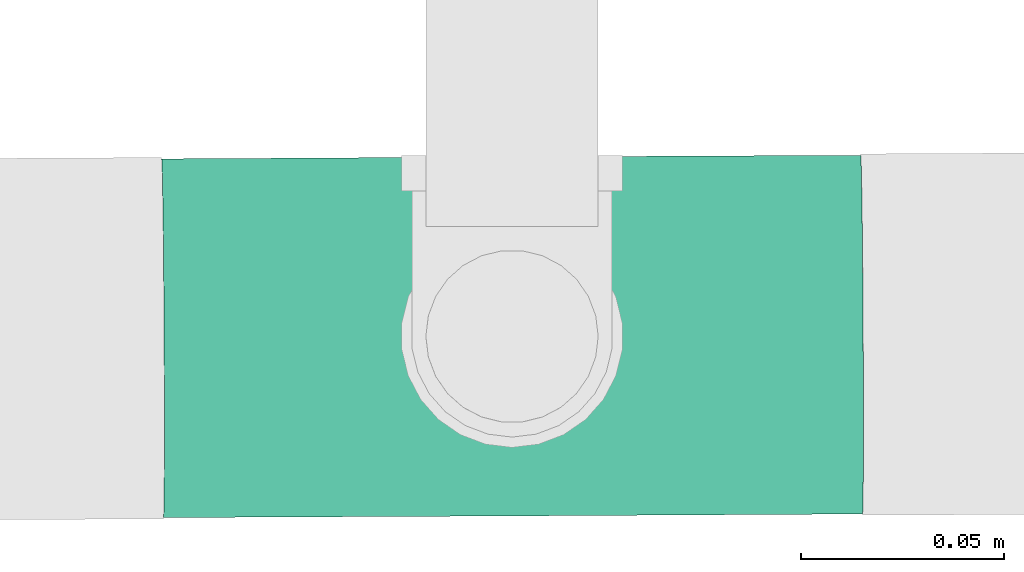
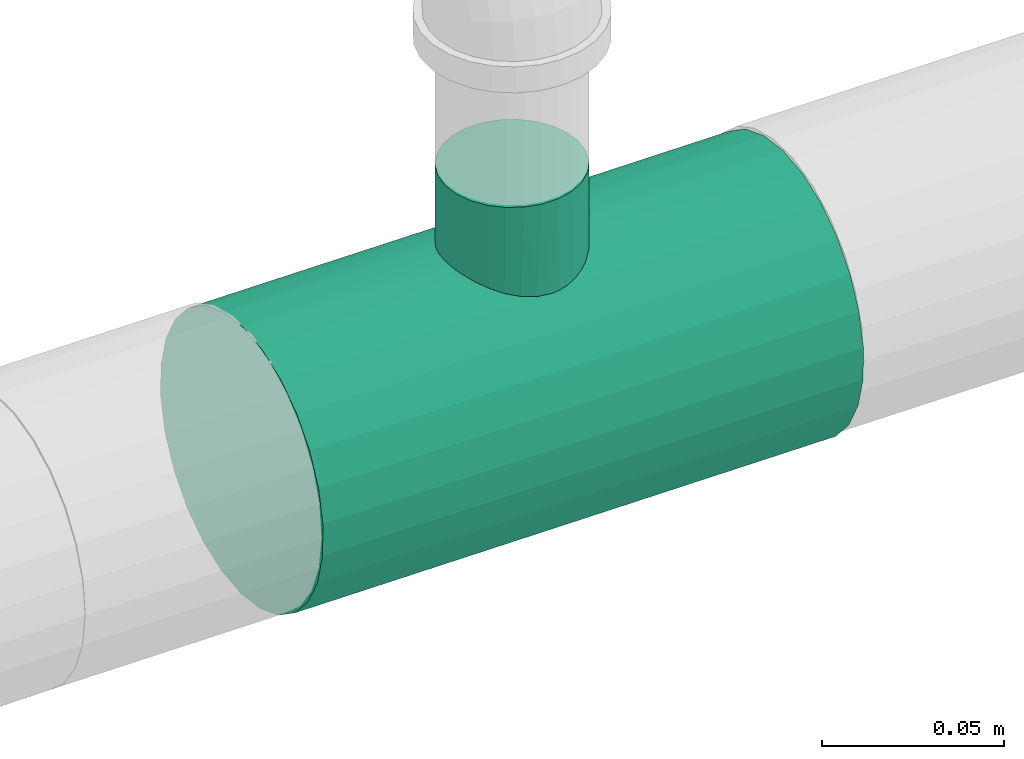
# One storey, part 2 of 7: 1 pipe fitting.
"""IFC4 building model written with IfcOpenShell, lengths in millimetres."""

from ifc_helpers import new_model, entity, si_unit, converted_unit, derived_unit, direction, frame, origin, place, context, subcontext, project, spatial, source, transform, mapped, type_object, type_shapes, element, save


model = new_model("IFC4")

# Units and contexts
model_context = context("Model", 3, precision=0.01, world=origin(), true_north=direction((6.12303176911189e-17, 1.0)))
body_context = subcontext(model_context, "Body", "Model", "MODEL_VIEW")
ifc_project = project(units=[si_unit("LENGTHUNIT", "METRE", prefix="MILLI"), si_unit("AREAUNIT", "SQUARE_METRE"), si_unit("VOLUMEUNIT", "CUBIC_METRE"), converted_unit("PLANEANGLEUNIT", "DEGREE", entity("IfcRatioMeasure", 0.0174532925199433), si_unit("PLANEANGLEUNIT", "RADIAN"), dimensions=[0, 0, 0, 0, 0, 0, 0]), si_unit("MASSUNIT", "GRAM", prefix="KILO"), derived_unit("MASSDENSITYUNIT", [(si_unit("MASSUNIT", "GRAM", prefix="KILO"), 1), (si_unit("LENGTHUNIT", "METRE"), -3)]), derived_unit("MOMENTOFINERTIAUNIT", [(si_unit("LENGTHUNIT", "METRE"), 4)]), si_unit("TIMEUNIT", "SECOND"), si_unit("FREQUENCYUNIT", "HERTZ"), si_unit("THERMODYNAMICTEMPERATUREUNIT", "DEGREE_CELSIUS"), derived_unit("THERMALTRANSMITTANCEUNIT", [(si_unit("MASSUNIT", "GRAM", prefix="KILO"), 1), (si_unit("THERMODYNAMICTEMPERATUREUNIT", "KELVIN"), -1), (si_unit("TIMEUNIT", "SECOND"), -3)]), derived_unit("VOLUMETRICFLOWRATEUNIT", [(si_unit("LENGTHUNIT", "METRE"), 3), (si_unit("TIMEUNIT", "SECOND"), -1)]), si_unit("ELECTRICCURRENTUNIT", "AMPERE"), si_unit("ELECTRICVOLTAGEUNIT", "VOLT"), si_unit("POWERUNIT", "WATT"), si_unit("FORCEUNIT", "NEWTON", prefix="KILO"), si_unit("ILLUMINANCEUNIT", "LUX"), si_unit("LUMINOUSFLUXUNIT", "LUMEN"), si_unit("LUMINOUSINTENSITYUNIT", "CANDELA"), derived_unit("USERDEFINED", [(si_unit("MASSUNIT", "GRAM", prefix="KILO"), -1), (si_unit("LENGTHUNIT", "METRE"), -2), (si_unit("TIMEUNIT", "SECOND"), 3), (si_unit("LUMINOUSFLUXUNIT", "LUMEN"), 1)]), derived_unit("LINEARVELOCITYUNIT", [(si_unit("LENGTHUNIT", "METRE"), 1), (si_unit("TIMEUNIT", "SECOND"), -1)]), si_unit("PRESSUREUNIT", "PASCAL"), derived_unit("USERDEFINED", [(si_unit("LENGTHUNIT", "METRE"), -2), (si_unit("MASSUNIT", "GRAM", prefix="KILO"), 1), (si_unit("TIMEUNIT", "SECOND"), -2)]), derived_unit("LINEARFORCEUNIT", [(si_unit("MASSUNIT", "GRAM", prefix="KILO"), 1), (si_unit("LENGTHUNIT", "METRE"), 1), (si_unit("TIMEUNIT", "SECOND"), -2), (si_unit("LENGTHUNIT", "METRE"), -1)]), derived_unit("PLANARFORCEUNIT", [(si_unit("MASSUNIT", "GRAM", prefix="KILO"), 1), (si_unit("LENGTHUNIT", "METRE"), 1), (si_unit("TIMEUNIT", "SECOND"), -2), (si_unit("LENGTHUNIT", "METRE"), -2)])], contexts=[model_context])

# Site, building, storey
site_placement = place(None, origin())
site = spatial("IfcSite", under=ifc_project, at=site_placement, CompositionType="ELEMENT")
building_placement = place(site_placement, origin())
building = spatial("IfcBuilding", under=site, at=building_placement, CompositionType="ELEMENT")
storey_placement = place(building_placement, origin())
storey = spatial("IfcBuildingStorey", under=building, at=storey_placement, Name="Ebene 1", CompositionType="ELEMENT", Elevation=0.0)

# Pipe fitting
pipe_fitting_type = type_object("IfcPipeFittingType", PredefinedType="NOTDEFINED")
cartesian_point_1 = entity("IfcCartesianPoint", [-86.0, -44.45, 0.0])
vertex_point_1 = entity("IfcVertexPoint", cartesian_point_1)
cartesian_point_2 = entity("IfcCartesianPoint", [-86.0, 44.45, 0.0])
vertex_point_2 = entity("IfcVertexPoint", cartesian_point_2)
cartesian_point_3 = entity("IfcCartesianPoint", [-86.0, 0.0, 0.0])
ifc_direction_1 = entity("IfcDirection", [-1.0, 0.0, 0.0])
ifc_direction_2 = entity("IfcDirection", [0.0, 1.0, 0.0])
edge_curve_1 = entity("IfcEdgeCurve", vertex_point_1, vertex_point_2, entity("IfcTrimmedCurve", entity("IfcCircle", entity("IfcAxis2Placement3D", cartesian_point_3, ifc_direction_1, ifc_direction_2), 44.45), [cartesian_point_1], [cartesian_point_2], True, "CARTESIAN"), True)
edge_curve_2 = entity("IfcEdgeCurve", vertex_point_2, vertex_point_1, entity("IfcTrimmedCurve", entity("IfcCircle", entity("IfcAxis2Placement3D", cartesian_point_3, ifc_direction_1, ifc_direction_2), 44.45), [cartesian_point_2], [cartesian_point_1], True, "CARTESIAN"), True)
ifc_direction_3 = entity("IfcDirection", [0.0, 0.0, 1.0])
cartesian_point_4 = entity("IfcCartesianPoint", [-20.7971681685193, -44.45, 0.0])
vertex_point_3 = entity("IfcVertexPoint", cartesian_point_4)
ifc_direction_4 = entity("IfcDirection", [1.0, 0.0, 0.0])
edge_curve_3 = entity("IfcEdgeCurve", vertex_point_1, vertex_point_3, entity("IfcTrimmedCurve", entity("IfcLine", cartesian_point_1, entity("IfcVector", ifc_direction_4, 304.8)), [cartesian_point_1], [cartesian_point_4], True, "CARTESIAN"), True)
cartesian_point_5 = entity("IfcCartesianPoint", [0.0, -39.0703008124086, 21.1970303209648])
vertex_point_4 = entity("IfcVertexPoint", cartesian_point_5)
edge_curve_4 = entity("IfcEdgeCurve", vertex_point_3, vertex_point_4, entity("IfcBSplineCurveWithKnots", 3, [cartesian_point_4, entity("IfcCartesianPoint", [-20.7894161768626, -44.45, 1.61926670883027]), entity("IfcCartesianPoint", [-20.4399996926229, -44.2752694055428, 4.76969277202615]), entity("IfcCartesianPoint", [-18.3360398797482, -43.3020524493489, 10.7769093251789]), entity("IfcCartesianPoint", [-14.6807233519097, -41.7728941152398, 15.4022309638281]), entity("IfcCartesianPoint", [-10.6730826588493, -40.5762821373456, 18.1669086000587]), entity("IfcCartesianPoint", [-8.61171482858813, -40.0775107284661, 19.2306799645881]), entity("IfcCartesianPoint", [-6.97915830976026, -39.7421088373454, 19.9129870653779]), entity("IfcCartesianPoint", [-5.28752366414808, -39.4610217520412, 20.462737400691]), entity("IfcCartesianPoint", [-3.00052122387521, -39.1863174791742, 20.9843263408341]), entity("IfcCartesianPoint", [-1.21705837571869, -39.0862641682384, 21.1676067128083]), cartesian_point_5], "UNSPECIFIED", False, "UNKNOWN", [4, 1, 1, 1, 1, 1, 1, 1, 1, 4], [0.0, 0.142857142857143, 0.285714285714286, 0.571428571428571, 0.678571428571429, 0.732142857142857, 0.785714285714286, 0.839285714285714, 0.892857142857143, 1.0], "UNSPECIFIED"), True)
cartesian_point_6 = entity("IfcCartesianPoint", [0.0, 44.45, 0.0])
vertex_point_5 = entity("IfcVertexPoint", cartesian_point_6)
cartesian_point_7 = entity("IfcCartesianPoint", [0.0, 0.0, 0.0])
edge_curve_5 = entity("IfcEdgeCurve", vertex_point_4, vertex_point_5, entity("IfcTrimmedCurve", entity("IfcCircle", entity("IfcAxis2Placement3D", cartesian_point_7, ifc_direction_1, ifc_direction_2), 44.45), [cartesian_point_5], [cartesian_point_6], True, "CARTESIAN"), True)
edge_curve_6 = entity("IfcEdgeCurve", vertex_point_5, vertex_point_2, entity("IfcTrimmedCurve", entity("IfcLine", cartesian_point_2, entity("IfcVector", ifc_direction_1, 304.8)), [cartesian_point_6], [cartesian_point_2], True, "CARTESIAN"), True)
cartesian_point_8 = entity("IfcCartesianPoint", [0.0, -39.0703008124085, -21.1970303209651])
vertex_point_6 = entity("IfcVertexPoint", cartesian_point_8)
edge_curve_7 = entity("IfcEdgeCurve", vertex_point_5, vertex_point_6, entity("IfcTrimmedCurve", entity("IfcCircle", entity("IfcAxis2Placement3D", cartesian_point_7, ifc_direction_1, ifc_direction_2), 44.45), [cartesian_point_6], [cartesian_point_8], True, "CARTESIAN"), True)
edge_curve_8 = entity("IfcEdgeCurve", vertex_point_6, vertex_point_3, entity("IfcBSplineCurveWithKnots", 3, [cartesian_point_8, entity("IfcCartesianPoint", [-1.62274450095824, -39.0915852868483, -21.157798843423]), entity("IfcCartesianPoint", [-4.75446055247149, -39.3101386510298, -20.7607749820248]), entity("IfcCartesianPoint", [-10.6981058379977, -40.4385788107955, -18.5550287703093]), entity("IfcCartesianPoint", [-16.1600850476128, -42.3479805522063, -14.0855294616885]), entity("IfcCartesianPoint", [-19.9806873775908, -44.0487569656944, -7.14794080038806]), entity("IfcCartesianPoint", [-20.7855401810342, -44.45, -2.42890006324572]), cartesian_point_4], "UNSPECIFIED", False, "UNKNOWN", [4, 1, 1, 1, 1, 4], [0.0, 0.142857142857143, 0.285714285714286, 0.571428571428571, 0.785714285714286, 1.0], "UNSPECIFIED"), True)
cartesian_point_9 = entity("IfcCartesianPoint", [86.0, -44.45, 0.0])
vertex_point_7 = entity("IfcVertexPoint", cartesian_point_9)
cartesian_point_10 = entity("IfcCartesianPoint", [86.0, 44.45, 0.0])
vertex_point_8 = entity("IfcVertexPoint", cartesian_point_10)
cartesian_point_11 = entity("IfcCartesianPoint", [86.0, 0.0, 0.0])
edge_curve_9 = entity("IfcEdgeCurve", vertex_point_7, vertex_point_8, entity("IfcTrimmedCurve", entity("IfcCircle", entity("IfcAxis2Placement3D", cartesian_point_11, ifc_direction_4, ifc_direction_2), 44.45), [cartesian_point_9], [cartesian_point_10], True, "CARTESIAN"), True)
edge_curve_10 = entity("IfcEdgeCurve", vertex_point_8, vertex_point_7, entity("IfcTrimmedCurve", entity("IfcCircle", entity("IfcAxis2Placement3D", cartesian_point_11, ifc_direction_4, ifc_direction_2), 44.45), [cartesian_point_10], [cartesian_point_9], True, "CARTESIAN"), True)
edge_curve_11 = entity("IfcEdgeCurve", vertex_point_8, vertex_point_5, entity("IfcTrimmedCurve", entity("IfcLine", cartesian_point_6, entity("IfcVector", ifc_direction_1, 304.8)), [cartesian_point_10], [cartesian_point_6], True, "CARTESIAN"), True)
cartesian_point_12 = entity("IfcCartesianPoint", [21.6045805268835, -44.45, 0.0])
vertex_point_9 = entity("IfcVertexPoint", cartesian_point_12)
edge_curve_12 = entity("IfcEdgeCurve", vertex_point_4, vertex_point_9, entity("IfcBSplineCurveWithKnots", 3, [cartesian_point_5, entity("IfcCartesianPoint", [1.66438566370079, -39.0621775691198, 21.212003057903]), entity("IfcCartesianPoint", [4.88457970874502, -39.2326753744964, 20.9041752682522]), entity("IfcCartesianPoint", [9.50257262879455, -40.0487413408101, 19.329411746474]), entity("IfcCartesianPoint", [13.5679663026614, -41.1858596793202, 16.8174467675685]), entity("IfcCartesianPoint", [17.5358931683773, -42.6178162355358, 12.9384393977207]), entity("IfcCartesianPoint", [20.743927053041, -44.0307420565211, 7.3011155274272]), entity("IfcCartesianPoint", [21.5920145015936, -44.45, 2.48196217209144]), cartesian_point_12], "UNSPECIFIED", False, "UNKNOWN", [4, 1, 1, 1, 1, 1, 4], [0.0, 0.142857142857143, 0.285714285714286, 0.428571428571429, 0.571428571428571, 0.785714285714286, 1.0], "UNSPECIFIED"), True)
edge_curve_13 = entity("IfcEdgeCurve", vertex_point_9, vertex_point_7, entity("IfcTrimmedCurve", entity("IfcLine", cartesian_point_12, entity("IfcVector", ifc_direction_4, 304.8)), [cartesian_point_12], [cartesian_point_9], True, "CARTESIAN"), True)
edge_curve_14 = entity("IfcEdgeCurve", vertex_point_9, vertex_point_6, entity("IfcBSplineCurveWithKnots", 3, [cartesian_point_12, entity("IfcCartesianPoint", [21.5962031766902, -44.45, -1.65464144806116]), entity("IfcCartesianPoint", [21.2290798982529, -44.2677642571246, -4.87065870117509]), entity("IfcCartesianPoint", [19.0147863930144, -43.2535531284132, -10.996203081152]), entity("IfcCartesianPoint", [15.1890485195202, -41.6760067352411, -15.6612143855601]), entity("IfcCartesianPoint", [11.0200533634964, -40.4704120165914, -18.400911475984]), entity("IfcCartesianPoint", [8.8815848444137, -39.9770010105982, -19.438428453853]), entity("IfcCartesianPoint", [7.18963129308835, -39.6503670366119, -20.0946839444955]), entity("IfcCartesianPoint", [5.43980656892788, -39.383421126627, -20.6113571932047]), entity("IfcCartesianPoint", [3.081460336296, -39.1357761845846, -21.0777561957276]), entity("IfcCartesianPoint", [1.24828924777558, -39.0642083799419, -21.2082598736686]), cartesian_point_8], "UNSPECIFIED", False, "UNKNOWN", [4, 1, 1, 1, 1, 1, 1, 1, 1, 4], [0.0, 0.142857142857143, 0.285714285714286, 0.571428571428571, 0.678571428571429, 0.732142857142857, 0.785714285714286, 0.839285714285714, 0.892857142857143, 1.0], "UNSPECIFIED"), True)
cartesian_point_13 = entity("IfcCartesianPoint", [-20.5633679258663, -70.1925358387771, 0.0])
vertex_point_10 = entity("IfcVertexPoint", cartesian_point_13)
cartesian_point_14 = entity("IfcCartesianPoint", [21.834883450849, -69.8074641612229, 0.0])
vertex_point_11 = entity("IfcVertexPoint", cartesian_point_14)
cartesian_point_15 = entity("IfcCartesianPoint", [0.635757762491333, -70.0, 0.0])
edge_curve_15 = entity("IfcEdgeCurve", vertex_point_10, vertex_point_11, entity("IfcTrimmedCurve", entity("IfcCircle", entity("IfcAxis2Placement3D", cartesian_point_15, entity("IfcDirection", [0.00908187918759948, -0.999958758884796, 0.0]), entity("IfcDirection", [0.999958758884796, 0.00908187918759948, 0.0])), 21.2), [cartesian_point_13], [cartesian_point_14], True, "CARTESIAN"), True)
edge_curve_16 = entity("IfcEdgeCurve", vertex_point_11, vertex_point_10, entity("IfcTrimmedCurve", entity("IfcCircle", entity("IfcAxis2Placement3D", cartesian_point_15, entity("IfcDirection", [0.00908187918759948, -0.999958758884796, 0.0]), entity("IfcDirection", [0.999958758884796, 0.00908187918759948, 0.0])), 21.2), [cartesian_point_14], [cartesian_point_13], True, "CARTESIAN"), True)
edge_curve_17 = entity("IfcEdgeCurve", vertex_point_11, vertex_point_9, entity("IfcTrimmedCurve", entity("IfcLine", cartesian_point_12, entity("IfcVector", entity("IfcDirection", [-0.00908187918759949, 0.999958758884796, 0.0]), 304.8)), [cartesian_point_14], [cartesian_point_12], True, "CARTESIAN"), True)
edge_curve_18 = entity("IfcEdgeCurve", vertex_point_3, vertex_point_10, entity("IfcTrimmedCurve", entity("IfcLine", cartesian_point_4, entity("IfcVector", entity("IfcDirection", [0.00908187918759945, -0.999958758884796, 0.0]), 304.8)), [cartesian_point_4], [cartesian_point_13], True, "CARTESIAN"), True)
shared_shape = source(origin(), body_context, "Body", "AdvancedBrep", [
    entity("IfcAdvancedBrep", entity("IfcClosedShell", [entity("IfcAdvancedFace", [entity("IfcFaceOuterBound", entity("IfcEdgeLoop", [entity("IfcOrientedEdge", None, None, edge_curve_1, True), entity("IfcOrientedEdge", None, None, edge_curve_2, True)]), True)], entity("IfcPlane", entity("IfcAxis2Placement3D", cartesian_point_3, ifc_direction_1, ifc_direction_3)), True), entity("IfcAdvancedFace", [entity("IfcFaceOuterBound", entity("IfcEdgeLoop", [entity("IfcOrientedEdge", None, None, edge_curve_1, False), entity("IfcOrientedEdge", None, None, edge_curve_3, True), entity("IfcOrientedEdge", None, None, edge_curve_4, True), entity("IfcOrientedEdge", None, None, edge_curve_5, True), entity("IfcOrientedEdge", None, None, edge_curve_6, True)]), True)], entity("IfcCylindricalSurface", entity("IfcAxis2Placement3D", cartesian_point_3, ifc_direction_1, ifc_direction_2), 44.45), True), entity("IfcAdvancedFace", [entity("IfcFaceOuterBound", entity("IfcEdgeLoop", [entity("IfcOrientedEdge", None, None, edge_curve_2, False), entity("IfcOrientedEdge", None, None, edge_curve_6, False), entity("IfcOrientedEdge", None, None, edge_curve_7, True), entity("IfcOrientedEdge", None, None, edge_curve_8, True), entity("IfcOrientedEdge", None, None, edge_curve_3, False)]), True)], entity("IfcCylindricalSurface", entity("IfcAxis2Placement3D", cartesian_point_3, ifc_direction_1, ifc_direction_2), 44.45), True), entity("IfcAdvancedFace", [entity("IfcFaceOuterBound", entity("IfcEdgeLoop", [entity("IfcOrientedEdge", None, None, edge_curve_9, True), entity("IfcOrientedEdge", None, None, edge_curve_10, True)]), True)], entity("IfcPlane", entity("IfcAxis2Placement3D", cartesian_point_11, ifc_direction_4, ifc_direction_3)), True), entity("IfcAdvancedFace", [entity("IfcFaceOuterBound", entity("IfcEdgeLoop", [entity("IfcOrientedEdge", None, None, edge_curve_10, False), entity("IfcOrientedEdge", None, None, edge_curve_11, True), entity("IfcOrientedEdge", None, None, edge_curve_5, False), entity("IfcOrientedEdge", None, None, edge_curve_12, True), entity("IfcOrientedEdge", None, None, edge_curve_13, True)]), True)], entity("IfcCylindricalSurface", entity("IfcAxis2Placement3D", cartesian_point_7, ifc_direction_1, ifc_direction_2), 44.45), True), entity("IfcAdvancedFace", [entity("IfcFaceOuterBound", entity("IfcEdgeLoop", [entity("IfcOrientedEdge", None, None, edge_curve_9, False), entity("IfcOrientedEdge", None, None, edge_curve_13, False), entity("IfcOrientedEdge", None, None, edge_curve_14, True), entity("IfcOrientedEdge", None, None, edge_curve_7, False), entity("IfcOrientedEdge", None, None, edge_curve_11, False)]), True)], entity("IfcCylindricalSurface", entity("IfcAxis2Placement3D", cartesian_point_7, ifc_direction_1, ifc_direction_2), 44.45), True), entity("IfcAdvancedFace", [entity("IfcFaceOuterBound", entity("IfcEdgeLoop", [entity("IfcOrientedEdge", None, None, edge_curve_15, True), entity("IfcOrientedEdge", None, None, edge_curve_16, True)]), True)], entity("IfcPlane", entity("IfcAxis2Placement3D", cartesian_point_15, entity("IfcDirection", [0.00908187918759948, -0.999958758884796, 0.0]), ifc_direction_3)), True), entity("IfcAdvancedFace", [entity("IfcFaceOuterBound", entity("IfcEdgeLoop", [entity("IfcOrientedEdge", None, None, edge_curve_16, False), entity("IfcOrientedEdge", None, None, edge_curve_17, True), entity("IfcOrientedEdge", None, None, edge_curve_12, False), entity("IfcOrientedEdge", None, None, edge_curve_4, False), entity("IfcOrientedEdge", None, None, edge_curve_18, True)]), True)], entity("IfcCylindricalSurface", entity("IfcAxis2Placement3D", cartesian_point_7, entity("IfcDirection", [-0.00908187918759948, 0.999958758884796, 0.0]), entity("IfcDirection", [0.999958758884796, 0.00908187918759948, 0.0])), 21.2), True), entity("IfcAdvancedFace", [entity("IfcFaceOuterBound", entity("IfcEdgeLoop", [entity("IfcOrientedEdge", None, None, edge_curve_15, False), entity("IfcOrientedEdge", None, None, edge_curve_18, False), entity("IfcOrientedEdge", None, None, edge_curve_8, False), entity("IfcOrientedEdge", None, None, edge_curve_14, False), entity("IfcOrientedEdge", None, None, edge_curve_17, False)]), True)], entity("IfcCylindricalSurface", entity("IfcAxis2Placement3D", cartesian_point_7, entity("IfcDirection", [-0.00908187918759948, 0.999958758884796, 0.0]), entity("IfcDirection", [0.999958758884796, 0.00908187918759948, 0.0])), 21.2), True)])),
])
type_shapes(pipe_fitting_type, [shared_shape])
pipe_fitting_placement = place(storey_placement, frame((10775.5510547739, 94908.7017672485, 3631.44657621103), z_axis=(0.00517702533472459, -0.99998659911455, 0.0), x_axis=(-0.999945358552014, -0.00517681182842635, 0.00908187918759934)))
element("IfcPipeFitting", 1, at=pipe_fitting_placement, inside=storey, type_object=pipe_fitting_type, PredefinedType="NOTDEFINED", context=body_context, shape_type="MappedRepresentation", body=[
    mapped(shared_shape, transform((0.0, 0.0, 0.0), scale=1.0)),
])

save(model, "model.ifc")
